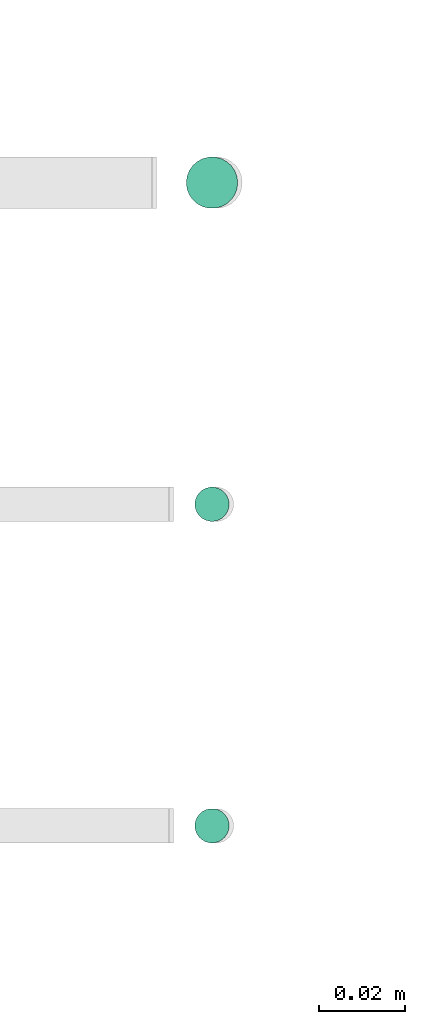
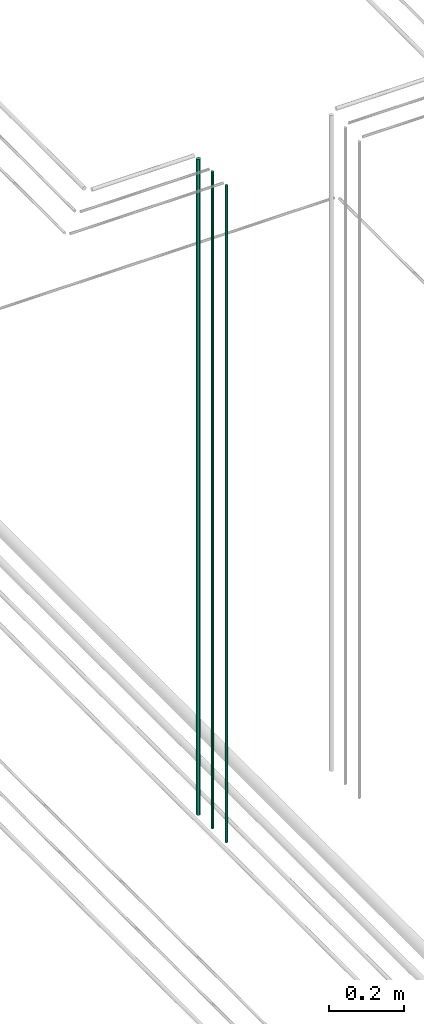
# One storey, part 44 of 331: 3 flow segments.
"""IFC2X3 building model written with IfcOpenShell, lengths in millimetres."""

from ifc_helpers import new_model, entity, si_unit, converted_unit, derived_unit, direction, frame, origin, origin_2d_with_axis, place, context, subcontext, project, spatial, circle, extrude, type_object, element, save


model = new_model("IFC2X3")

# Units and contexts
model_context = context("Model", 3, precision=0.01, world=origin(), true_north=direction((6.12303176911189e-17, 1.0)))
body_context = subcontext(model_context, "Body", "Model", "MODEL_VIEW")
ifc_project = project(units=[si_unit("LENGTHUNIT", "METRE", prefix="MILLI"), si_unit("AREAUNIT", "SQUARE_METRE"), si_unit("VOLUMEUNIT", "CUBIC_METRE"), converted_unit("PLANEANGLEUNIT", "DEGREE", entity("IfcRatioMeasure", 0.0174532925199433), si_unit("PLANEANGLEUNIT", "RADIAN"), dimensions=[0, 0, 0, 0, 0, 0, 0]), si_unit("MASSUNIT", "GRAM", prefix="KILO"), derived_unit("MASSDENSITYUNIT", [(si_unit("MASSUNIT", "GRAM", prefix="KILO"), 1), (si_unit("LENGTHUNIT", "METRE"), -3)]), derived_unit("MOMENTOFINERTIAUNIT", [(si_unit("LENGTHUNIT", "METRE"), 4)]), si_unit("TIMEUNIT", "SECOND"), si_unit("FREQUENCYUNIT", "HERTZ"), si_unit("THERMODYNAMICTEMPERATUREUNIT", "DEGREE_CELSIUS"), derived_unit("THERMALTRANSMITTANCEUNIT", [(si_unit("MASSUNIT", "GRAM", prefix="KILO"), 1), (si_unit("THERMODYNAMICTEMPERATUREUNIT", "KELVIN"), -1), (si_unit("TIMEUNIT", "SECOND"), -3)]), derived_unit("VOLUMETRICFLOWRATEUNIT", [(si_unit("LENGTHUNIT", "METRE"), 3), (si_unit("TIMEUNIT", "SECOND"), -1)]), derived_unit("MASSFLOWRATEUNIT", [(si_unit("MASSUNIT", "GRAM", prefix="KILO"), 1), (si_unit("TIMEUNIT", "SECOND"), -1)]), derived_unit("ROTATIONALFREQUENCYUNIT", [(si_unit("TIMEUNIT", "SECOND"), -1)]), si_unit("ELECTRICCURRENTUNIT", "AMPERE"), si_unit("ELECTRICVOLTAGEUNIT", "VOLT"), si_unit("POWERUNIT", "WATT"), si_unit("FORCEUNIT", "NEWTON", prefix="KILO"), si_unit("ILLUMINANCEUNIT", "LUX"), si_unit("LUMINOUSFLUXUNIT", "LUMEN"), si_unit("LUMINOUSINTENSITYUNIT", "CANDELA"), derived_unit("USERDEFINED", [(si_unit("MASSUNIT", "GRAM", prefix="KILO"), -1), (si_unit("LENGTHUNIT", "METRE"), -2), (si_unit("TIMEUNIT", "SECOND"), 3), (si_unit("LUMINOUSFLUXUNIT", "LUMEN"), 1)]), derived_unit("LINEARVELOCITYUNIT", [(si_unit("LENGTHUNIT", "METRE"), 1), (si_unit("TIMEUNIT", "SECOND"), -1)]), si_unit("PRESSUREUNIT", "PASCAL"), derived_unit("USERDEFINED", [(si_unit("LENGTHUNIT", "METRE"), -2), (si_unit("MASSUNIT", "GRAM", prefix="KILO"), 1), (si_unit("TIMEUNIT", "SECOND"), -2)]), derived_unit("LINEARFORCEUNIT", [(si_unit("MASSUNIT", "GRAM", prefix="KILO"), 1), (si_unit("LENGTHUNIT", "METRE"), 1), (si_unit("TIMEUNIT", "SECOND"), -2), (si_unit("LENGTHUNIT", "METRE"), -1)]), derived_unit("PLANARFORCEUNIT", [(si_unit("MASSUNIT", "GRAM", prefix="KILO"), 1), (si_unit("LENGTHUNIT", "METRE"), 1), (si_unit("TIMEUNIT", "SECOND"), -2), (si_unit("LENGTHUNIT", "METRE"), -2)])], contexts=[model_context])

# Site, building, storey
site_placement = place(None, frame((0.0, -0.00077364408347762, 0.0)))
site = spatial("IfcSite", under=ifc_project, at=site_placement, CompositionType="ELEMENT")
building_placement = place(site_placement, origin())
building = spatial("IfcBuilding", under=site, at=building_placement, CompositionType="ELEMENT")
storey_placement = place(building_placement, origin())
storey = spatial("IfcBuildingStorey", under=building, at=storey_placement, CompositionType="ELEMENT", Elevation=0.0)

# Flow segments
pipe_segment_type = type_object("IfcPipeSegmentType", PredefinedType="NOTDEFINED")
flow_segment_1_placement = place(storey_placement, frame((53156.8310109464, 1343.89349484376, 16890.0)))
element("IfcFlowSegment", 1, at=flow_segment_1_placement, inside=storey, type_object=pipe_segment_type, context=body_context, shape_type="SweptSolid", body=[
    extrude(circle(Radius=6.0, at=origin_2d_with_axis()), frame((7.59527223591454, 7.59527223591589, 0.0)), (0.0, 0.0, 1.0), 2146.0),
])
flow_segment_2_placement = place(storey_placement, frame((53158.8310109464, 1270.89349484376, 16890.0)))
element("IfcFlowSegment", 2, at=flow_segment_2_placement, inside=storey, type_object=pipe_segment_type, context=body_context, shape_type="SweptSolid", body=[
    extrude(circle(Radius=4.0, at=origin_2d_with_axis()), frame((5.59527223591499, 5.5952722359158, 0.0)), (0.0, 0.0, 1.0), 2150.00000000001),
])
flow_segment_3_placement = place(storey_placement, frame((53158.8310109464, 1195.89349484376, 16890.0)))
element("IfcFlowSegment", 3, at=flow_segment_3_placement, inside=storey, type_object=pipe_segment_type, context=body_context, shape_type="SweptSolid", body=[
    extrude(circle(Radius=4.0, at=origin_2d_with_axis()), frame((5.59527223591499, 5.59527223591607, 0.0)), (0.0, 0.0, 1.0), 2150.00000000001),
])

save(model, "model.ifc")
